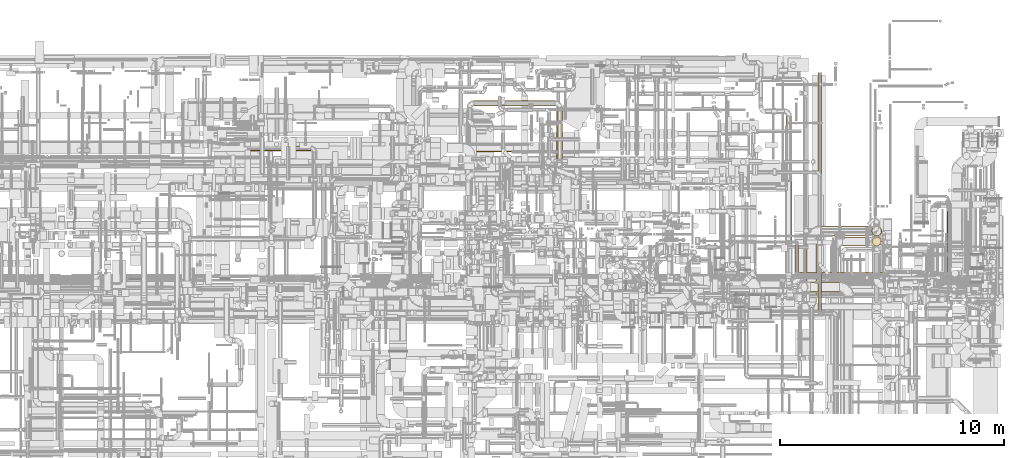
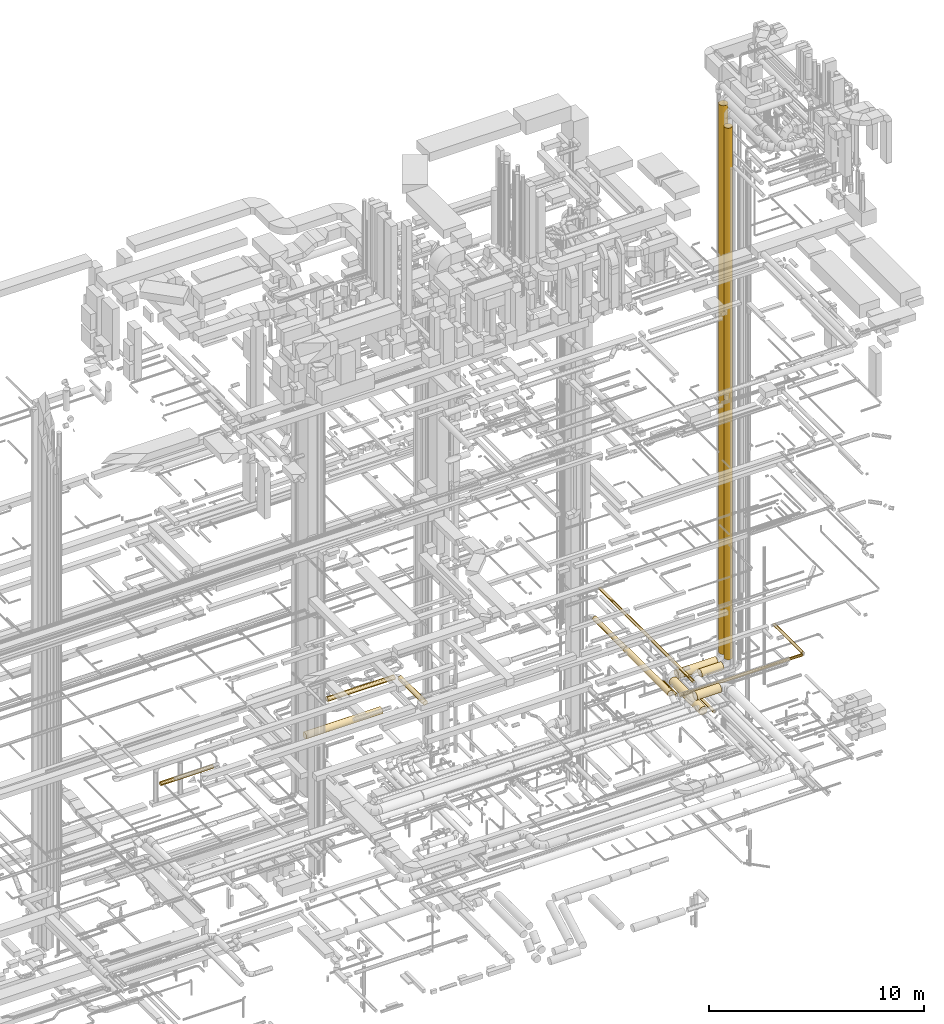
# One storey, part 2 of 337: 17 coverings.
"""IFC2X3 building model written with IfcOpenShell, lengths in millimetres."""

from ifc_helpers import new_model, entity, si_unit, converted_unit, derived_unit, direction, frame, origin, origin_2d_with_axis, place, context, subcontext, project, spatial, circle, extrude, element, save


model = new_model("IFC2X3")

# Units and contexts
model_context = context("Model", 3, precision=0.01, world=origin(), true_north=direction((6.12303176911189e-17, 1.0)))
body_context = subcontext(model_context, "Body", "Model", "MODEL_VIEW")
ifc_project = project(units=[si_unit("LENGTHUNIT", "METRE", prefix="MILLI"), si_unit("AREAUNIT", "SQUARE_METRE"), si_unit("VOLUMEUNIT", "CUBIC_METRE"), converted_unit("PLANEANGLEUNIT", "DEGREE", entity("IfcRatioMeasure", 0.0174532925199433), si_unit("PLANEANGLEUNIT", "RADIAN"), dimensions=[0, 0, 0, 0, 0, 0, 0]), si_unit("MASSUNIT", "GRAM", prefix="KILO"), derived_unit("MASSDENSITYUNIT", [(si_unit("MASSUNIT", "GRAM", prefix="KILO"), 1), (si_unit("LENGTHUNIT", "METRE"), -3)]), derived_unit("MOMENTOFINERTIAUNIT", [(si_unit("LENGTHUNIT", "METRE"), 4)]), si_unit("TIMEUNIT", "SECOND"), si_unit("FREQUENCYUNIT", "HERTZ"), si_unit("THERMODYNAMICTEMPERATUREUNIT", "DEGREE_CELSIUS"), derived_unit("THERMALTRANSMITTANCEUNIT", [(si_unit("MASSUNIT", "GRAM", prefix="KILO"), 1), (si_unit("THERMODYNAMICTEMPERATUREUNIT", "KELVIN"), -1), (si_unit("TIMEUNIT", "SECOND"), -3)]), derived_unit("VOLUMETRICFLOWRATEUNIT", [(si_unit("LENGTHUNIT", "METRE"), 3), (si_unit("TIMEUNIT", "SECOND"), -1)]), derived_unit("MASSFLOWRATEUNIT", [(si_unit("MASSUNIT", "GRAM", prefix="KILO"), 1), (si_unit("TIMEUNIT", "SECOND"), -1)]), derived_unit("ROTATIONALFREQUENCYUNIT", [(si_unit("TIMEUNIT", "SECOND"), -1)]), si_unit("ELECTRICCURRENTUNIT", "AMPERE"), si_unit("ELECTRICVOLTAGEUNIT", "VOLT"), si_unit("POWERUNIT", "WATT"), si_unit("FORCEUNIT", "NEWTON", prefix="KILO"), si_unit("ILLUMINANCEUNIT", "LUX"), si_unit("LUMINOUSFLUXUNIT", "LUMEN"), si_unit("LUMINOUSINTENSITYUNIT", "CANDELA"), derived_unit("USERDEFINED", [(si_unit("MASSUNIT", "GRAM", prefix="KILO"), -1), (si_unit("LENGTHUNIT", "METRE"), -2), (si_unit("TIMEUNIT", "SECOND"), 3), (si_unit("LUMINOUSFLUXUNIT", "LUMEN"), 1)]), derived_unit("LINEARVELOCITYUNIT", [(si_unit("LENGTHUNIT", "METRE"), 1), (si_unit("TIMEUNIT", "SECOND"), -1)]), si_unit("PRESSUREUNIT", "PASCAL"), derived_unit("USERDEFINED", [(si_unit("LENGTHUNIT", "METRE"), -2), (si_unit("MASSUNIT", "GRAM", prefix="KILO"), 1), (si_unit("TIMEUNIT", "SECOND"), -2)]), derived_unit("LINEARFORCEUNIT", [(si_unit("MASSUNIT", "GRAM", prefix="KILO"), 1), (si_unit("LENGTHUNIT", "METRE"), 1), (si_unit("TIMEUNIT", "SECOND"), -2), (si_unit("LENGTHUNIT", "METRE"), -1)]), derived_unit("PLANARFORCEUNIT", [(si_unit("MASSUNIT", "GRAM", prefix="KILO"), 1), (si_unit("LENGTHUNIT", "METRE"), 1), (si_unit("TIMEUNIT", "SECOND"), -2), (si_unit("LENGTHUNIT", "METRE"), -2)])], contexts=[model_context])

# Site, building, storey
site_placement = place(None, origin())
site = spatial("IfcSite", under=ifc_project, at=site_placement, CompositionType="ELEMENT")
building_placement = place(site_placement, origin())
building = spatial("IfcBuilding", under=site, at=building_placement, CompositionType="ELEMENT")
storey_placement = place(building_placement, origin())
storey = spatial("IfcBuildingStorey", under=building, at=storey_placement, CompositionType="ELEMENT", Elevation=0.0)

# Coverings
covering_1_placement = place(storey_placement, frame((39457.29, 15839.8, 3443.4)))
element("IfcCovering", 1, at=covering_1_placement, inside=storey, PredefinedType="INSULATION", context=body_context, shape_type="SweptSolid", body=[
    extrude(circle(Radius=105.0, at=origin_2d_with_axis()), frame((0.0, 106.6, 106.6), z_axis=(1.0, 0.0, 0.0), x_axis=(0.0, -1.0, 0.0)), (0.0, 0.0, 1.0), 2821.87500000001),
])
covering_2_placement = place(storey_placement, frame((63483.85, 10372.07, 3448.4)))
element("IfcCovering", 2, at=covering_2_placement, inside=storey, PredefinedType="INSULATION", context=body_context, shape_type="SweptSolid", body=[
    extrude(circle(Radius=150.0, at=origin_2d_with_axis()), frame((151.6, 0.0, 151.6), z_axis=(0.0, 1.0, 0.0), x_axis=(1.0, 0.0, 0.0)), (0.0, 0.0, 1.0), 4100.63203062379),
])
covering_3_placement = place(storey_placement, frame((63508.85, 14522.7, 3473.4)))
element("IfcCovering", 3, at=covering_3_placement, inside=storey, PredefinedType="INSULATION", context=body_context, shape_type="SweptSolid", body=[
    extrude(circle(Radius=125.0, at=origin_2d_with_axis()), frame((126.6, 0.0, 126.6), z_axis=(0.0, 1.0, 0.0), x_axis=(1.0, 0.0, 0.0)), (0.0, 0.0, 1.0), 2876.69047558311),
])
covering_4_placement = place(storey_placement, frame((63925.59, 10424.99, 3273.4)))
element("IfcCovering", 4, at=covering_4_placement, inside=storey, PredefinedType="INSULATION", context=body_context, shape_type="SweptSolid", body=[
    extrude(circle(Radius=75.0, at=origin_2d_with_axis()), frame((76.6, 0.0, 76.6), z_axis=(0.0, 1.0, 0.0), x_axis=(1.0, 0.0, 0.0)), (0.0, 0.0, 1.0), 1237.60000000001),
])
covering_5_placement = place(storey_placement, frame((64102.18, 10248.39, 3273.4)))
element("IfcCovering", 5, at=covering_5_placement, inside=storey, PredefinedType="INSULATION", context=body_context, shape_type="SweptSolid", body=[
    extrude(circle(Radius=75.0, at=origin_2d_with_axis()), frame((0.0, 76.6, 76.6), z_axis=(1.0, 0.0, 0.0), x_axis=(0.0, 1.0, 0.0)), (0.0, 0.0, 1.0), 6585.54965025766),
])
covering_6_placement = place(storey_placement, frame((70711.14, 10424.99, 3273.4)))
element("IfcCovering", 6, at=covering_6_placement, inside=storey, PredefinedType="INSULATION", context=body_context, shape_type="SweptSolid", body=[
    extrude(circle(Radius=75.0, at=origin_2d_with_axis()), frame((76.6, 0.0, 76.6), z_axis=(0.0, 1.0, 0.0), x_axis=(-1.0, 0.0, 0.0)), (0.0, 0.0, 1.0), 2697.59999999997),
])
covering_7_placement = place(storey_placement, frame((53261.67, 15415.07, 3453.4)))
element("IfcCovering", 7, at=covering_7_placement, inside=storey, PredefinedType="INSULATION", context=body_context, shape_type="SweptSolid", body=[
    extrude(circle(Radius=125.0, at=origin_2d_with_axis()), frame((126.6, 0.0, 126.6), z_axis=(0.0, 1.0, 0.0), x_axis=(1.0, 0.0, 0.0)), (0.0, 0.0, 1.0), 2350.00010685499),
])
covering_8_placement = place(storey_placement, frame((49573.27, 17838.48, 3453.4)))
element("IfcCovering", 8, at=covering_8_placement, inside=storey, PredefinedType="INSULATION", context=body_context, shape_type="SweptSolid", body=[
    extrude(circle(Radius=125.0, at=origin_2d_with_axis()), frame((0.0, 126.6, 126.6), z_axis=(1.0, 0.0, 0.0), x_axis=(0.0, -1.0, 0.0)), (0.0, 0.0, 1.0), 3615.00000000002),
])
covering_9_placement = place(storey_placement, frame((47237.72, 15793.32, 3365.9)))
element("IfcCovering", 9, at=covering_9_placement, inside=storey, PredefinedType="INSULATION", context=body_context, shape_type="SweptSolid", body=[
    extrude(circle(Radius=182.5, at=origin_2d_with_axis()), frame((0.0, 184.1, 184.1), z_axis=(1.0, 0.0, 0.0), x_axis=(0.0, -1.0, 0.0)), (0.0, 0.0, 1.0), 4095.00022628647),
])
covering_10_placement = place(storey_placement, frame((66038.23, 11585.06, 2845.9)))
element("IfcCovering", 10, at=covering_10_placement, inside=storey, PredefinedType="INSULATION", context=body_context, shape_type="SweptSolid", body=[
    extrude(circle(Radius=202.5, at=origin_2d_with_axis()), frame((0.0, 204.1, 204.1), z_axis=(1.0, 0.0, 0.0), x_axis=(0.0, 1.0, 0.0)), (0.0, 0.0, 1.0), 1169.95144825251),
])
covering_11_placement = place(storey_placement, frame((67354.95, 11585.06, 3405.02)))
element("IfcCovering", 11, at=covering_11_placement, inside=storey, PredefinedType="INSULATION", context=body_context, shape_type="SweptSolid", body=[
    extrude(circle(Radius=202.5, at=origin_2d_with_axis()), frame((208.23, 204.1, 0.03), z_axis=(-0.000136960044590436, 0.0, 0.999999990620973), x_axis=(0.999999990620973, 0.0, 0.000136960044590436)), (0.0, 0.0, 1.0), 30179.9517342104),
])
covering_12_placement = place(storey_placement, frame((65048.27, 12023.32, 2823.4)))
element("IfcCovering", 12, at=covering_12_placement, inside=storey, PredefinedType="INSULATION", context=body_context, shape_type="SweptSolid", body=[
    extrude(circle(Radius=225.0, at=origin_2d_with_axis()), frame((0.0, 226.6, 226.6), z_axis=(1.0, 0.0, 0.0), x_axis=(0.0, -1.0, 0.0)), (0.0, 0.0, 1.0), 2114.94669087573),
])
covering_13_placement = place(storey_placement, frame((64421.67, 9074.91, 2823.4)))
element("IfcCovering", 13, at=covering_13_placement, inside=storey, PredefinedType="INSULATION", context=body_context, shape_type="SweptSolid", body=[
    extrude(circle(Radius=225.0, at=origin_2d_with_axis()), frame((226.6, 0.0, 226.6), z_axis=(0.0, 1.0, 0.0), x_axis=(-1.0, 0.0, 0.0)), (0.0, 0.0, 1.0), 2775.00000000001),
])
covering_14_placement = place(storey_placement, frame((64605.16, 9523.4, 3273.4)))
element("IfcCovering", 14, at=covering_14_placement, inside=storey, PredefinedType="INSULATION", context=body_context, shape_type="SweptSolid", body=[
    extrude(circle(Radius=225.0, at=origin_2d_with_axis()), frame((0.0, 226.6, 226.6), z_axis=(1.0, 0.0, 0.0), x_axis=(0.0, -1.0, 0.0)), (0.0, 0.0, 1.0), 1293.81173910657),
])
covering_15_placement = place(storey_placement, frame((64940.15, 10579.14, 3573.4)))
element("IfcCovering", 15, at=covering_15_placement, inside=storey, PredefinedType="INSULATION", context=body_context, shape_type="SweptSolid", body=[
    extrude(circle(Radius=75.0, at=origin_2d_with_axis()), frame((76.6, 0.0, 76.6), z_axis=(0.0, 1.0, 0.0), x_axis=(-1.0, 0.0, 0.0)), (0.0, 0.0, 1.0), 8755.19859995445),
])
covering_16_placement = place(storey_placement, frame((64940.15, 8696.67, 3023.4)))
element("IfcCovering", 16, at=covering_16_placement, inside=storey, PredefinedType="INSULATION", context=body_context, shape_type="SweptSolid", body=[
    extrude(circle(Radius=75.0, at=origin_2d_with_axis()), frame((76.6, 0.0, 76.6), z_axis=(0.0, 1.0, 0.0), x_axis=(1.0, 0.0, 0.0)), (0.0, 0.0, 1.0), 1682.46889627103),
])
covering_17_placement = place(storey_placement, frame((67332.51, 12023.32, 3450.02)))
element("IfcCovering", 17, at=covering_17_placement, inside=storey, PredefinedType="INSULATION", context=body_context, shape_type="SweptSolid", body=[
    extrude(circle(Radius=225.0, at=origin_2d_with_axis()), frame((230.7, 226.6, 0.03), z_axis=(-0.000131785563679762, 0.0, 0.999999991316283), x_axis=(0.999999991316283, 0.0, 0.000131785563679762)), (0.0, 0.0, 1.0), 31149.9469683989),
])

save(model, "model.ifc")
